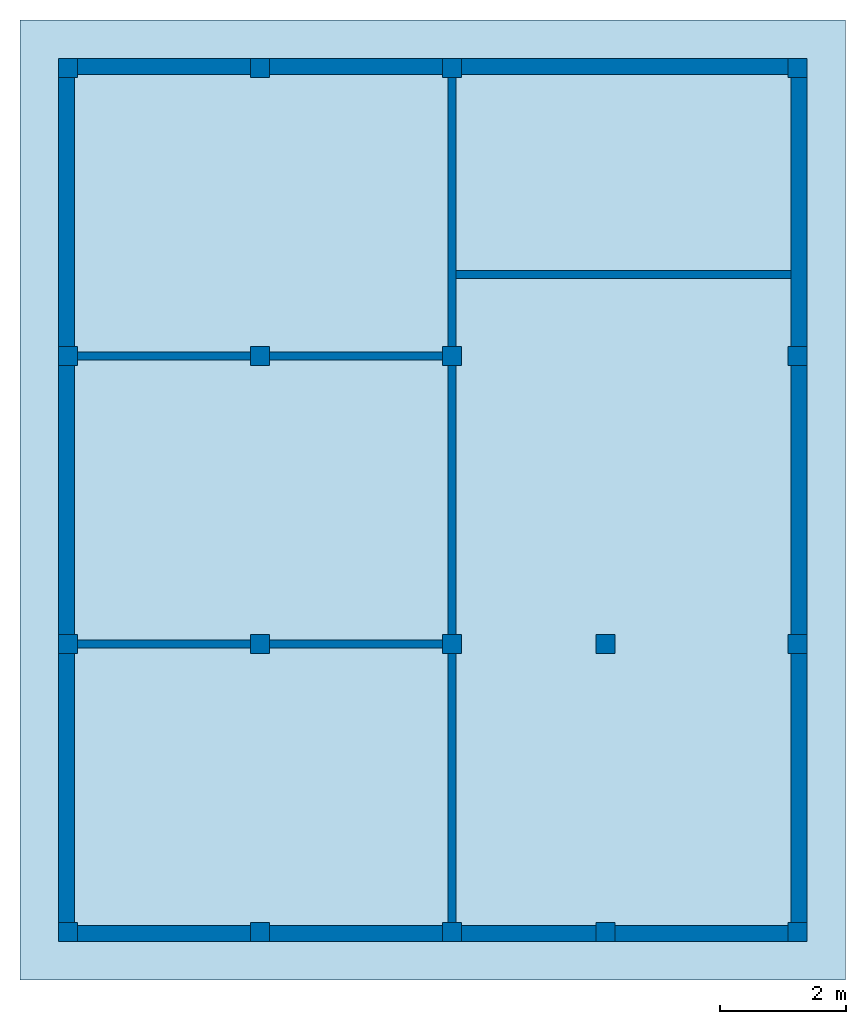
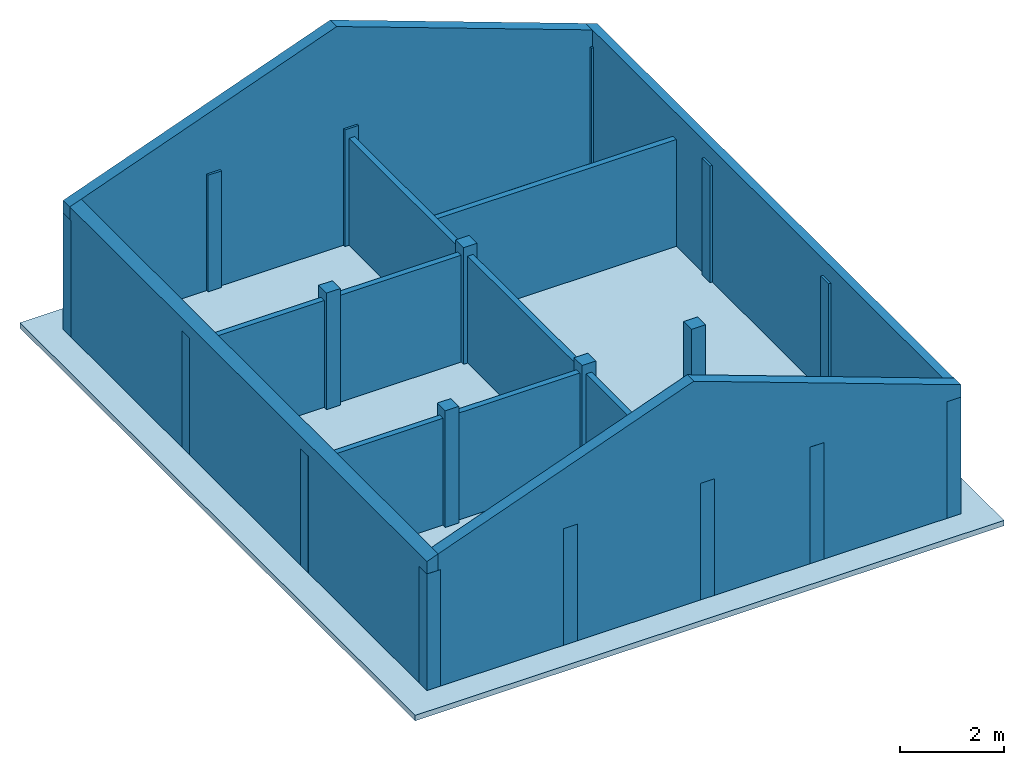
# One storey: 18 columns, 10 walls, 1 slab.
"""IFC2X3 building model written with IfcOpenShell, lengths in feet."""

from ifc_helpers import new_model, entity, si_unit, converted_unit, derived_unit, direction, frame, frame_2d, origin, origin_2d_with_axis, place, context, subcontext, project, spatial, polyline, rectangle, extrude, clip, bounded_halfspace, source, transform, mapped, material, layer, layer_set, layer_usage, type_object, type_shapes, element, save


model = new_model("IFC2X3")

# Units and contexts
model_context = context("Model", 3, precision=0.0001, world=origin(), true_north=direction((6.123031769111886e-17, 1.0)))
body_context = subcontext(model_context, "Body", "Model", "MODEL_VIEW")
ifc_project = project(units=[converted_unit("LENGTHUNIT", "FOOT", entity("IfcLengthMeasure", 0.3048), si_unit("LENGTHUNIT", "METRE"), dimensions=[1, 0, 0, 0, 0, 0, 0]), converted_unit("AREAUNIT", "SQUARE FOOT", entity("IfcAreaMeasure", 0.09290304), si_unit("AREAUNIT", "SQUARE_METRE"), dimensions=[2, 0, 0, 0, 0, 0, 0]), converted_unit("VOLUMEUNIT", "CUBIC FOOT", entity("IfcVolumeMeasure", 0.028316846592000004), si_unit("VOLUMEUNIT", "CUBIC_METRE"), dimensions=[3, 0, 0, 0, 0, 0, 0]), converted_unit("PLANEANGLEUNIT", "DEGREE", entity("IfcPlaneAngleMeasure", 0.017453292519943278), si_unit("PLANEANGLEUNIT", "RADIAN"), dimensions=[0, 0, 0, 0, 0, 0, 0]), si_unit("MASSUNIT", "GRAM", prefix="KILO"), derived_unit("MASSDENSITYUNIT", [(si_unit("MASSUNIT", "GRAM", prefix="KILO"), 1), (si_unit("LENGTHUNIT", "METRE"), -3)]), derived_unit("IONCONCENTRATIONUNIT", [(si_unit("MASSUNIT", "GRAM", prefix="KILO"), 1), (si_unit("LENGTHUNIT", "METRE"), -3)]), derived_unit("MOMENTOFINERTIAUNIT", [(si_unit("LENGTHUNIT", "METRE"), 4)]), si_unit("TIMEUNIT", "SECOND"), si_unit("FREQUENCYUNIT", "HERTZ"), si_unit("THERMODYNAMICTEMPERATUREUNIT", "DEGREE_CELSIUS"), derived_unit("THERMALTRANSMITTANCEUNIT", [(si_unit("MASSUNIT", "GRAM", prefix="KILO"), 1), (si_unit("THERMODYNAMICTEMPERATUREUNIT", "KELVIN"), -1), (si_unit("TIMEUNIT", "SECOND"), -3)]), derived_unit("THERMALCONDUCTANCEUNIT", [(si_unit("MASSUNIT", "GRAM", prefix="KILO"), 1), (si_unit("THERMODYNAMICTEMPERATUREUNIT", "KELVIN"), -1), (si_unit("TIMEUNIT", "SECOND"), -3), (si_unit("LENGTHUNIT", "METRE"), 1)]), derived_unit("VOLUMETRICFLOWRATEUNIT", [(si_unit("LENGTHUNIT", "METRE"), 3), (si_unit("TIMEUNIT", "SECOND"), -1)]), derived_unit("MASSFLOWRATEUNIT", [(si_unit("MASSUNIT", "GRAM", prefix="KILO"), 1), (si_unit("TIMEUNIT", "SECOND"), -1)]), derived_unit("ROTATIONALFREQUENCYUNIT", [(si_unit("TIMEUNIT", "SECOND"), -1)]), si_unit("ELECTRICCURRENTUNIT", "AMPERE"), si_unit("ELECTRICVOLTAGEUNIT", "VOLT"), si_unit("POWERUNIT", "WATT"), converted_unit("FORCEUNIT", "KIP", entity("IfcForceMeasure", 2.088543423315013e-05), si_unit("FORCEUNIT", "NEWTON"), dimensions=[1, 1, -2, 0, 0, 0, 0]), si_unit("ILLUMINANCEUNIT", "LUX"), si_unit("LUMINOUSFLUXUNIT", "LUMEN"), si_unit("LUMINOUSINTENSITYUNIT", "CANDELA"), si_unit("ENERGYUNIT", "JOULE"), derived_unit("USERDEFINED", [(si_unit("MASSUNIT", "GRAM", prefix="KILO"), -1), (si_unit("LENGTHUNIT", "METRE"), -2), (si_unit("TIMEUNIT", "SECOND"), 3), (si_unit("LUMINOUSFLUXUNIT", "LUMEN"), 1)]), derived_unit("USERDEFINED", [(si_unit("MASSUNIT", "GRAM", prefix="KILO"), 1), (si_unit("TIMEUNIT", "SECOND"), -3), (si_unit("LENGTHUNIT", "METRE"), 3), (si_unit("ELECTRICCURRENTUNIT", "AMPERE"), -2)]), derived_unit("SOUNDPOWERUNIT", [(si_unit("MASSUNIT", "GRAM", prefix="KILO"), 1), (si_unit("TIMEUNIT", "SECOND"), -3), (si_unit("LENGTHUNIT", "METRE"), 2)]), derived_unit("SOUNDPRESSUREUNIT", [(si_unit("MASSUNIT", "GRAM", prefix="KILO"), 1), (si_unit("LENGTHUNIT", "METRE"), -1), (si_unit("TIMEUNIT", "SECOND"), -2)]), derived_unit("LINEARVELOCITYUNIT", [(si_unit("LENGTHUNIT", "METRE"), 1), (si_unit("TIMEUNIT", "SECOND"), -1)]), si_unit("PRESSUREUNIT", "PASCAL"), derived_unit("USERDEFINED", [(si_unit("MASSUNIT", "GRAM", prefix="KILO"), 1), (si_unit("LENGTHUNIT", "METRE"), -2), (si_unit("TIMEUNIT", "SECOND"), -2)]), derived_unit("LINEARFORCEUNIT", [(si_unit("MASSUNIT", "GRAM", prefix="KILO"), 1), (si_unit("TIMEUNIT", "SECOND"), -2)]), derived_unit("PLANARFORCEUNIT", [(si_unit("MASSUNIT", "GRAM", prefix="KILO"), 1), (si_unit("LENGTHUNIT", "METRE"), -1), (si_unit("TIMEUNIT", "SECOND"), -2)]), derived_unit("SPECIFICHEATCAPACITYUNIT", [(si_unit("THERMODYNAMICTEMPERATUREUNIT", "KELVIN"), -1), (si_unit("LENGTHUNIT", "METRE"), 2), (si_unit("TIMEUNIT", "SECOND"), -2)]), derived_unit("HEATFLUXDENSITYUNIT", [(si_unit("MASSUNIT", "GRAM", prefix="KILO"), 1), (si_unit("TIMEUNIT", "SECOND"), -3)]), derived_unit("HEATINGVALUEUNIT", [(si_unit("LENGTHUNIT", "METRE"), 2), (si_unit("TIMEUNIT", "SECOND"), -2)]), derived_unit("VAPORPERMEABILITYUNIT", [(si_unit("LENGTHUNIT", "METRE"), -1), (si_unit("TIMEUNIT", "SECOND"), 1)]), derived_unit("DYNAMICVISCOSITYUNIT", [(si_unit("MASSUNIT", "GRAM", prefix="KILO"), 1), (si_unit("TIMEUNIT", "SECOND"), -1), (si_unit("LENGTHUNIT", "METRE"), -1)]), derived_unit("THERMALEXPANSIONCOEFFICIENTUNIT", [(si_unit("THERMODYNAMICTEMPERATUREUNIT", "KELVIN"), -1)]), derived_unit("MODULUSOFELASTICITYUNIT", [(si_unit("MASSUNIT", "GRAM", prefix="KILO"), 1), (si_unit("LENGTHUNIT", "METRE"), -1), (si_unit("TIMEUNIT", "SECOND"), -2)]), derived_unit("ISOTHERMALMOISTURECAPACITYUNIT", [(si_unit("LENGTHUNIT", "METRE"), 3), (si_unit("MASSUNIT", "GRAM", prefix="KILO"), -1)]), derived_unit("MOISTUREDIFFUSIVITYUNIT", [(si_unit("TIMEUNIT", "SECOND"), -1), (si_unit("LENGTHUNIT", "METRE"), 2)]), derived_unit("MASSPERLENGTHUNIT", [(si_unit("MASSUNIT", "GRAM", prefix="KILO"), 1), (si_unit("LENGTHUNIT", "METRE"), -1)]), derived_unit("THERMALRESISTANCEUNIT", [(si_unit("MASSUNIT", "GRAM", prefix="KILO"), -1), (si_unit("TIMEUNIT", "SECOND"), 3), (si_unit("THERMODYNAMICTEMPERATUREUNIT", "KELVIN"), 1)]), derived_unit("ACCELERATIONUNIT", [(si_unit("LENGTHUNIT", "METRE"), 1), (si_unit("TIMEUNIT", "SECOND"), -2)]), derived_unit("ANGULARVELOCITYUNIT", [(si_unit("TIMEUNIT", "SECOND"), -1), (si_unit("PLANEANGLEUNIT", "RADIAN"), 1)]), derived_unit("LINEARSTIFFNESSUNIT", [(si_unit("MASSUNIT", "GRAM", prefix="KILO"), 1), (si_unit("TIMEUNIT", "SECOND"), -2)]), derived_unit("WARPINGCONSTANTUNIT", [(si_unit("LENGTHUNIT", "METRE"), 6)]), derived_unit("LINEARMOMENTUNIT", [(si_unit("MASSUNIT", "GRAM", prefix="KILO"), 1), (si_unit("LENGTHUNIT", "METRE"), 1), (si_unit("TIMEUNIT", "SECOND"), -2)]), derived_unit("TORQUEUNIT", [(si_unit("MASSUNIT", "GRAM", prefix="KILO"), 1), (si_unit("LENGTHUNIT", "METRE"), 2), (si_unit("TIMEUNIT", "SECOND"), -2)])], contexts=[model_context])

# Site, building, storey
site_placement = place(None, origin())
site = spatial("IfcSite", under=ifc_project, at=site_placement, CompositionType="ELEMENT")
building_placement = place(site_placement, origin())
building = spatial("IfcBuilding", under=site, at=building_placement, CompositionType="ELEMENT")
storey_placement = place(building_placement, frame((0.0, 0.0, 18.833333333333574)))
storey = spatial("IfcBuildingStorey", under=building, at=storey_placement, Name="Second Floor", CompositionType="ELEMENT", Elevation=18.833333333333574)

# Columns
ifc_material_1 = material(Name="Concrete, Cast-in-Place gray")
column_type = type_object("IfcColumnType", PredefinedType="COLUMN", material=ifc_material_1)
shared_shape = source(origin(), body_context, "Body", "SweptSolid", [
    extrude(rectangle(XDim=0.9999999999999999, YDim=0.9999999999999999, at=origin_2d_with_axis()), frame((0.0, 0.0, 18.833333333333574), z_axis=(0.0, 0.0, 1.0), x_axis=(-1.0, 0.0, 0.0)), (0.0, 0.0, 1.0), 9.00000000000162),
])
type_shapes(column_type, [shared_shape])
for number, where in (
    (1, (9.874478019162162, -49.84124484724893, -18.833333333333574)),
    (2, (29.874478019162154, -49.841244847248994, -18.833333333333574)),
    (3, (37.87447801916216, -49.84124484724902, -18.833333333333574)),
    (4, (47.87447801916217, -49.84124484724906, -18.833333333333574)),
    (5, (19.874478019162158, -49.841244847248966, -18.833333333333574)),
    (6, (9.874478019162186, -34.84124484724893, -18.833333333333574)),
    (7, (29.87447801916219, -34.841244847248994, -18.833333333333574)),
    (8, (37.87447801916219, -34.84124484724902, -18.833333333333574)),
    (9, (47.87447801916219, -34.84124484724906, -18.833333333333574)),
    (10, (19.874478019162183, -34.841244847248966, -18.833333333333574)),
    (11, (9.874478019162211, -19.841244847248934, -18.833333333333574)),
    (12, (29.87447801916221, -19.841244847248998, -18.833333333333574)),
    (13, (47.87447801916221, -19.841244847249058, -18.833333333333574)),
    (14, (19.874478019162204, -19.841244847248966, -18.833333333333574)),
    (15, (9.874478019162234, -4.841244847248884, -18.833333333333574)),
    (16, (29.874478019162233, -4.841244847248948, -18.833333333333574)),
    (17, (47.87447801916224, -4.841244847249006, -18.833333333333574)),
    (18, (19.87447801916223, -4.841244847248915, -18.833333333333574)),
):
    element("IfcColumn", number, at=place(storey_placement, frame(where)), inside=storey, type_object=column_type, material=ifc_material_1, context=body_context, shape_type="MappedRepresentation", body=[
        mapped(shared_shape, transform((0.0, 0.0, 0.0), scale=1.0)),
    ])

# Slab
ifc_material_2 = material(Name="Default Floor")
ifc_layer_1 = layer(ifc_material_2, 0.4166666666666667)
ifc_layer_set_1 = layer_set([ifc_layer_1])
ifc_layer_usage_1 = layer_usage(ifc_layer_set_1, "AXIS3", "POSITIVE", 0.0)
slab_type = type_object("IfcSlabType", PredefinedType="FLOOR", material=ifc_layer_set_1)
slab_placement = place(storey_placement, origin())
element("IfcSlab", 19, at=slab_placement, inside=storey, type_object=slab_type, material=ifc_layer_usage_1, PredefinedType="FLOOR", context=body_context, shape_type="SweptSolid", body=[
    extrude(rectangle(XDim=50.00000000000018, YDim=42.99999999999993, at=origin_2d_with_axis()), frame((28.874478019162204, -27.34124484724897, 0.0), z_axis=(0.0, 0.0, -1.0), x_axis=(0.0, 1.0, 0.0)), (0.0, 0.0, 1.0), 0.41666666666666785),
])

# Walls
ifc_material_3 = material(Name="Default Wall")
ifc_layer_2 = layer(ifc_material_3, 0.041666666666666664)
ifc_layer_3 = layer(ifc_material_3, 0.75)
ifc_layer_4 = layer(ifc_material_3, 0.041666666666666664)
ifc_layer_set_2 = layer_set([ifc_layer_2, ifc_layer_3, ifc_layer_4])
ifc_layer_usage_2 = layer_usage(ifc_layer_set_2, "AXIS2", "NEGATIVE", 0.4166666666666667)
wall_type_1 = type_object("IfcWallType", PredefinedType="STANDARD", material=ifc_layer_set_2)
wall_1_placement = place(storey_placement, frame((9.374478019162236, -4.757911513915549, 0.0)))
element("IfcWallStandardCase", 20, at=wall_1_placement, inside=storey, type_object=wall_type_1, material=ifc_layer_usage_2, context=body_context, shape_type="Clipping", body=[
    clip(clip(extrude(rectangle(XDim=38.1666666666666, YDim=0.8333333333333339, at=frame_2d((19.0833333333333, 0.0), x_axis=(-1.0, 0.0))), origin(), (0.0, 0.0, 1.0), 17.060041586258592), bounded_halfspace(frame((0.0, -0.4166666666666661, 9.96262201806725), z_axis=(-0.3420201433256691, 0.0, 0.9396926207859082), x_axis=(0.0, -1.0, 0.0)), False, frame((0.0, -0.4166666666666661, 9.96262201806725)), polyline([(0.0, 0.0), (0.8333333333333286, 0.0), (19.50000000000106, 0.0), (19.500000000001066, 0.833333333333333), (0.0, 0.833333333333333), (0.0, 0.0)]))), bounded_halfspace(frame((19.500000000001055, -0.4166666666666661, 17.060041586258592), z_axis=(0.3420201433256702, 0.0, 0.9396926207859079), x_axis=(0.0, 1.0, 0.0)), False, frame((19.500000000001055, -0.4166666666666661, 17.060041586258592)), polyline([(0.0, 0.0), (18.666666666665545, 0.0), (18.666666666665545, 0.833333333333333), (0.0, 0.833333333333333), (0.0, 0.0)]))),
])
wall_2_placement = place(storey_placement, frame((9.791144685828902, -50.34124484724887, 0.0), z_axis=(0.0, 0.0, 1.0), x_axis=(0.0, 1.0, 0.0)))
element("IfcWallStandardCase", 21, at=wall_2_placement, inside=storey, type_object=wall_type_1, material=ifc_layer_usage_2, context=body_context, shape_type="Clipping", body=[
    clip(extrude(rectangle(XDim=45.16666666666666, YDim=0.8333333333333321, at=frame_2d((22.58333333333333, 0.0), x_axis=(-1.0, 0.0))), origin(), (0.0, 0.0, 1.0), 10.265930546622414), bounded_halfspace(frame((0.0, -0.41666666666666785, 10.265930546622414), z_axis=(0.0, 0.3420201433256691, 0.9396926207859082), x_axis=(-1.0, 0.0, 0.0)), False, frame((0.0, -0.41666666666666785, 10.265930546622414)), polyline([(0.0, 0.0), (0.8333333333333286, 0.0), (45.16666666666666, 0.0), (45.16666666666666, 0.8333333333333339), (0.0, 0.8333333333333339), (0.0, 0.0)]))),
])
wall_3_placement = place(storey_placement, frame((48.37447801916217, -49.924578180582216, 0.0), z_axis=(0.0, 0.0, 1.0), x_axis=(-1.0, 0.0, 0.0)))
element("IfcWallStandardCase", 22, at=wall_3_placement, inside=storey, type_object=wall_type_1, material=ifc_layer_usage_2, context=body_context, shape_type="Clipping", body=[
    clip(clip(extrude(rectangle(XDim=38.1666666666666, YDim=0.8333333333333286, at=frame_2d((19.0833333333333, 0.0), x_axis=(-1.0, 0.0))), origin(), (0.0, 0.0, 1.0), 17.060041586258592), bounded_halfspace(frame((19.499999999998867, -0.4166666666666714, 17.060041586258592), z_axis=(0.3420201433256691, 0.0, 0.9396926207859082), x_axis=(0.0, 1.0, 0.0)), False, frame((19.499999999998867, -0.4166666666666714, 17.060041586258592)), polyline([(0.0, 0.0), (18.666666666667734, 0.0), (18.666666666667734, 0.8333333333333286), (0.0, 0.8333333333333357), (0.0, 0.0)]))), bounded_halfspace(frame((0.0, -0.4166666666666714, 9.962622018068018), z_axis=(-0.3420201433256702, 0.0, 0.9396926207859079), x_axis=(0.0, -1.0, 0.0)), False, frame((0.0, -0.4166666666666714, 9.962622018068018)), polyline([(0.0, 0.0), (0.8333333333333357, 0.0), (19.49999999999887, 0.0), (19.49999999999887, 0.8333333333333357), (0.0, 0.8333333333333357), (0.0, 0.0)]))),
])
wall_4_placement = place(storey_placement, frame((47.957811352495504, -4.3412448472488805, 0.0), z_axis=(0.0, 0.0, 1.0), x_axis=(0.0, -1.0, 0.0)))
element("IfcWallStandardCase", 23, at=wall_4_placement, inside=storey, type_object=wall_type_1, material=ifc_layer_usage_2, context=body_context, shape_type="Clipping", body=[
    clip(extrude(rectangle(XDim=45.166666666666664, YDim=0.8333333333333286, at=frame_2d((22.583333333333332, 0.0), x_axis=(-1.0, 0.0))), origin(), (0.0, 0.0, 1.0), 10.265930546623181), bounded_halfspace(frame((0.0, -0.4166666666666714, 10.265930546623181), z_axis=(0.0, 0.3420201433256702, 0.9396926207859079), x_axis=(-1.0, 0.0, 0.0)), False, frame((0.0, -0.4166666666666714, 10.265930546623181)), polyline([(0.0, 0.0), (0.8333333333333375, 0.0), (45.166666666666664, 0.0), (45.166666666666664, 0.8333333333333357), (0.0, 0.8333333333333357), (0.0, 0.0)]))),
])
ifc_layer_5 = layer(ifc_material_3, 0.4166666666666667)
ifc_layer_set_3 = layer_set([ifc_layer_5])
ifc_layer_usage_3 = layer_usage(ifc_layer_set_3, "AXIS2", "NEGATIVE", 0.20833333333333334)
wall_type_2 = type_object("IfcWallType", PredefinedType="STANDARD", material=ifc_layer_set_3)
wall_5_placement = place(storey_placement, frame((10.37447801916221, -19.841244847248937, 0.0)))
element("IfcWallStandardCase", 24, at=wall_5_placement, inside=storey, type_object=wall_type_2, material=ifc_layer_usage_3, context=body_context, shape_type="SweptSolid", body=[
    extrude(rectangle(XDim=19.0, YDim=0.4166666666666643, at=frame_2d((9.5, 0.0), x_axis=(-1.0, 0.0))), origin(), (0.0, 0.0, 1.0), 8.249999999998622),
])
wall_6_placement = place(storey_placement, frame((29.87447801916221, -19.341244847248994, 0.0), z_axis=(0.0, 0.0, 1.0), x_axis=(0.0, 1.0, 0.0)))
element("IfcWallStandardCase", 25, at=wall_6_placement, inside=storey, type_object=wall_type_2, material=ifc_layer_usage_3, context=body_context, shape_type="SweptSolid", body=[
    extrude(rectangle(XDim=14.000000000000046, YDim=0.4166666666666643, at=frame_2d((7.000000000000023, 0.0), x_axis=(-1.0, 0.0))), origin(), (0.0, 0.0, 1.0), 8.249999999998622),
])
wall_7_placement = place(storey_placement, frame((29.87447801916221, -20.341244847249, 0.0), z_axis=(0.0, 0.0, 1.0), x_axis=(0.0, -1.0, 0.0)))
element("IfcWallStandardCase", 26, at=wall_7_placement, inside=storey, type_object=wall_type_2, material=ifc_layer_usage_3, context=body_context, shape_type="SweptSolid", body=[
    extrude(rectangle(XDim=13.999999999999986, YDim=0.4166666666666643, at=frame_2d((6.999999999999993, 0.0), x_axis=(-1.0, 0.0))), origin(), (0.0, 0.0, 1.0), 8.249999999998622),
])
wall_8_placement = place(storey_placement, frame((29.37447801916219, -34.841244847248994, 0.0), z_axis=(0.0, 0.0, 1.0), x_axis=(-1.0, 0.0, 0.0)))
element("IfcWallStandardCase", 27, at=wall_8_placement, inside=storey, type_object=wall_type_2, material=ifc_layer_usage_3, context=body_context, shape_type="SweptSolid", body=[
    extrude(rectangle(XDim=19.000000000000007, YDim=0.4166666666666714, at=frame_2d((9.500000000000004, 0.0), x_axis=(-1.0, 0.0))), origin(), (0.0, 0.0, 1.0), 8.249999999998622),
])
wall_9_placement = place(storey_placement, frame((29.87447801916219, -35.341244847249, 0.0), z_axis=(0.0, 0.0, 1.0), x_axis=(0.0, -1.0, 0.0)))
element("IfcWallStandardCase", 28, at=wall_9_placement, inside=storey, type_object=wall_type_2, material=ifc_layer_usage_3, context=body_context, shape_type="SweptSolid", body=[
    extrude(rectangle(XDim=13.999999999999986, YDim=0.4166666666666643, at=frame_2d((6.999999999999993, 0.0), x_axis=(-1.0, 0.0))), origin(), (0.0, 0.0, 1.0), 8.249999999998622),
])
wall_10_placement = place(storey_placement, frame((30.082811352495554, -15.591244847248992, 0.0)))
element("IfcWallStandardCase", 29, at=wall_10_placement, inside=storey, type_object=wall_type_2, material=ifc_layer_usage_3, context=body_context, shape_type="SweptSolid", body=[
    extrude(rectangle(XDim=17.45833333333328, YDim=0.41666666666666785, at=frame_2d((8.72916666666664, -1.3877787807814457e-16), x_axis=(-1.0, 0.0))), origin(), (0.0, 0.0, 1.0), 8.249999999998622),
])

save(model, "model.ifc")
